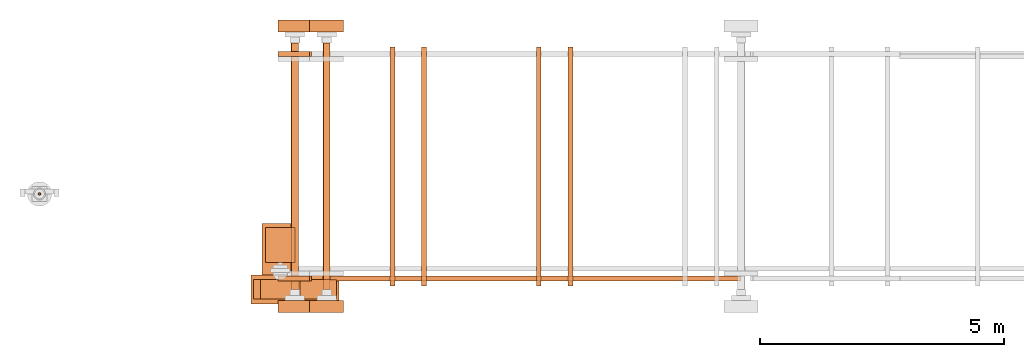
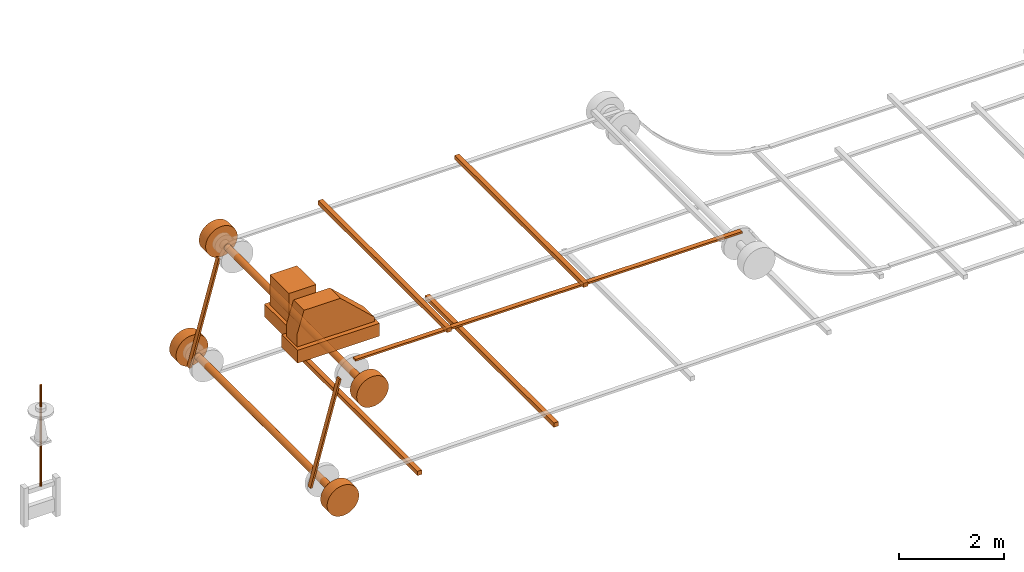
# One storey, part 1 of 6: 27 proxies.
"""IFC2X3 building model written with IfcOpenShell, lengths in millimetres."""

from ifc_helpers import new_model, entity, si_unit, converted_unit, direction, frame, origin_with_axes, origin_2d_with_axis, place, context, project, spatial, polyline, rectangle, circle, outline, extrude, source, transform, mapped, element, save


model = new_model("IFC2X3")

# Units and contexts
model_context = context("Model", 3, precision=1e-05, world=origin_with_axes(), true_north=direction((0.0, 1.0)))
ifc_project = project(units=[si_unit("LENGTHUNIT", "METRE", prefix="MILLI"), si_unit("AREAUNIT", "SQUARE_METRE"), si_unit("VOLUMEUNIT", "CUBIC_METRE"), converted_unit("PLANEANGLEUNIT", "DEGREE", entity("IfcPlaneAngleMeasure", 0.017453293), si_unit("PLANEANGLEUNIT", "RADIAN"), dimensions=[0, 0, 0, 0, 0, 0, 0]), si_unit("SOLIDANGLEUNIT", "STERADIAN"), si_unit("MASSUNIT", "GRAM"), si_unit("TIMEUNIT", "SECOND"), si_unit("THERMODYNAMICTEMPERATUREUNIT", "DEGREE_CELSIUS"), si_unit("LUMINOUSINTENSITYUNIT", "LUMEN")], contexts=[model_context])

# Site, building, storey
site_placement = place(None, origin_with_axes())
site = spatial("IfcSite", under=ifc_project, at=site_placement, CompositionType="ELEMENT")
building_placement = place(site_placement, origin_with_axes())
building = spatial("IfcBuilding", under=site, at=building_placement, Name="Default Building", CompositionType="ELEMENT")
storey_placement = place(building_placement, frame((0.0, 0.0, 16000.0), z_axis=(0.0, 0.0, 1.0), x_axis=(1.0, 0.0, 0.0)))
storey = spatial("IfcBuildingStorey", under=building, at=storey_placement, Name="3FL", CompositionType="ELEMENT", Elevation=16000.0)

# Proxies
shared_shape_1 = source(origin_with_axes(), model_context, "Body", "SweptSolid", [
    extrude(circle(Radius=25.0, at=origin_2d_with_axis()), origin_with_axes(), (0.0, 0.0, 1.0), 2350.0),
])
proxy_1_placement = place(storey_placement, frame((11140.362524, 23295.346832, 1533.035808), z_axis=(0.0, 0.0, 1.0), x_axis=(1.0, 0.0, 0.0)))
element("IfcBuildingElementProxy", 1, at=proxy_1_placement, inside=storey, context=model_context, shape_type="MappedRepresentation", body=[
    mapped(shared_shape_1, transform((0.0, 0.0, 0.0))),
])
shared_shape_2 = source(origin_with_axes(), model_context, "Body", "SweptSolid", [
    extrude(circle(Radius=350.0, at=origin_2d_with_axis()), frame((0.0, 0.0, 0.0), z_axis=(-4.43734259186819e-31, -2.95822839457879e-31, 1.0), x_axis=(1.0, 5.91669923873109e-47, 4.43734259186819e-31)), (0.0, 0.0, 1.0), 250.0),
])
proxy_2_placement = place(storey_placement, frame((16376.115417, 20861.795807, 836.521767), z_axis=(2.22044604925031e-16, 1.0, 1.60814287233912e-16), x_axis=(4.93038065763132e-32, 1.60814287233912e-16, -1.0)))
element("IfcBuildingElementProxy", 2, at=proxy_2_placement, inside=storey, context=model_context, shape_type="MappedRepresentation", body=[
    mapped(shared_shape_2, transform((0.0, 0.0, 0.0))),
])
shared_shape_3 = source(origin_with_axes(), model_context, "Body", "SweptSolid", [
    extrude(rectangle(XDim=100.0, YDim=4900.0, at=origin_2d_with_axis()), origin_with_axes(), (0.0, 0.0, 1.0), 100.0),
])
proxy_3_placement = place(storey_placement, frame((18376.115454, 23861.796014, 395.200808), z_axis=(0.0, 0.0, 1.0), x_axis=(1.0, 0.0, 0.0)))
element("IfcBuildingElementProxy", 3, at=proxy_3_placement, inside=storey, context=model_context, shape_type="MappedRepresentation", body=[
    mapped(shared_shape_3, transform((0.0, 0.0, 0.0))),
])
shared_shape_4 = source(origin_with_axes(), model_context, "Body", "SweptSolid", [
    extrude(outline(polyline([(-1198.796501, -19.752936), (1209.725039, -19.752936), (1197.960199, 22.776105), (-1198.796501, 22.776105), (-1198.796501, -19.752936)])), frame((0.0, 0.0, 0.0), z_axis=(2.43389396721937e-32, 3.84584135769826e-33, 1.0), x_axis=(1.0, 5.71916645986104e-18, -4.35741649917612e-32)), (0.0, 0.0, 1.0), 100.0),
])
proxy_4_placement = place(storey_placement, frame((16374.079133, 26211.795807, 1997.191257), z_axis=(-8.91995163426052e-17, -1.0, 6.95977817373063e-17), x_axis=(-0.266617368178496, -4.32963728535968e-17, -0.963802458486993)))
element("IfcBuildingElementProxy", 4, at=proxy_4_placement, inside=storey, context=model_context, shape_type="MappedRepresentation", body=[
    mapped(shared_shape_4, transform((0.0, 0.0, 0.0))),
])
shared_shape_5 = source(origin_with_axes(), model_context, "Body", "SweptSolid", [
    extrude(outline(polyline([(-1198.796501, -19.752936), (1209.725039, -19.752936), (1197.960199, 22.776105), (-1198.796501, 22.776105), (-1198.796501, -19.752936)])), frame((0.0, 0.0, 0.0), z_axis=(2.43389396721937e-32, 3.84584135769826e-33, 1.0), x_axis=(1.0, 5.71916645986104e-18, -4.35741649917612e-32)), (0.0, 0.0, 1.0), 100.0),
])
proxy_5_placement = place(storey_placement, frame((16374.079133, 21611.795807, 1997.191257), z_axis=(-8.91995163426052e-17, -1.0, 6.95977817373063e-17), x_axis=(-0.266617368178496, -4.32963728535968e-17, -0.963802458486993)))
element("IfcBuildingElementProxy", 5, at=proxy_5_placement, inside=storey, context=model_context, shape_type="MappedRepresentation", body=[
    mapped(shared_shape_5, transform((0.0, 0.0, 0.0))),
])
shared_shape_6 = source(origin_with_axes(), model_context, "Body", "SweptSolid", [
    extrude(outline(polyline([(-4250.0, -21.26452), (4250.0, -21.26452), (4250.0, 21.26452), (-4250.0, 21.26452), (-4250.0, -21.26452)])), origin_with_axes(), (0.0, 0.0, 1.0), 100.0),
])
proxy_6_placement = place(storey_placement, frame((21276.115417, 21611.795807, 3467.786287), z_axis=(0.0, -1.0, 0.0), x_axis=(1.0, 0.0, 0.0)))
element("IfcBuildingElementProxy", 6, at=proxy_6_placement, inside=storey, context=model_context, shape_type="MappedRepresentation", body=[
    mapped(shared_shape_6, transform((0.0, 0.0, 0.0))),
])
shared_shape_7 = source(origin_with_axes(), model_context, "Body", "SweptSolid", [
    extrude(circle(Radius=75.0, at=origin_2d_with_axis()), frame((0.0, 0.0, 0.0), z_axis=(-4.43734259186819e-31, -2.95822839457879e-31, 1.0), x_axis=(1.0, 5.91669923873109e-47, 4.43734259186819e-31)), (0.0, 0.0, 1.0), 5050.0),
])
proxy_7_placement = place(storey_placement, frame((17026.115417, 21336.795807, 3139.050808), z_axis=(2.22044604925031e-16, 1.0, 1.60814287233912e-16), x_axis=(4.93038065763132e-32, 1.60814287233912e-16, -1.0)))
element("IfcBuildingElementProxy", 7, at=proxy_7_placement, inside=storey, context=model_context, shape_type="MappedRepresentation", body=[
    mapped(shared_shape_7, transform((0.0, 0.0, 0.0))),
])
shared_shape_8 = source(origin_with_axes(), model_context, "Body", "SweptSolid", [
    extrude(circle(Radius=350.0, at=origin_2d_with_axis()), frame((0.0, 0.0, 0.0), z_axis=(-4.43734259186819e-31, -2.95822839457879e-31, 1.0), x_axis=(1.0, 5.91669923873109e-47, 4.43734259186819e-31)), (0.0, 0.0, 1.0), 250.0),
])
proxy_8_placement = place(storey_placement, frame((17026.115417, 26611.795807, 3139.050808), z_axis=(2.22044604925031e-16, 1.0, 1.60814287233912e-16), x_axis=(4.93038065763132e-32, 1.60814287233912e-16, -1.0)))
element("IfcBuildingElementProxy", 8, at=proxy_8_placement, inside=storey, context=model_context, shape_type="MappedRepresentation", body=[
    mapped(shared_shape_8, transform((0.0, 0.0, 0.0))),
])
shared_shape_9 = source(origin_with_axes(), model_context, "Body", "SweptSolid", [
    extrude(circle(Radius=350.0, at=origin_2d_with_axis()), frame((0.0, 0.0, 0.0), z_axis=(-4.43734259186819e-31, -2.95822839457879e-31, 1.0), x_axis=(1.0, 5.91669923873109e-47, 4.43734259186819e-31)), (0.0, 0.0, 1.0), 250.0),
])
proxy_9_placement = place(storey_placement, frame((17026.115417, 20861.795807, 3139.050808), z_axis=(2.22044604925031e-16, 1.0, 1.60814287233912e-16), x_axis=(4.93038065763132e-32, 1.60814287233912e-16, -1.0)))
element("IfcBuildingElementProxy", 9, at=proxy_9_placement, inside=storey, context=model_context, shape_type="MappedRepresentation", body=[
    mapped(shared_shape_9, transform((0.0, 0.0, 0.0))),
])
shared_shape_10 = source(origin_with_axes(), model_context, "Body", "SweptSolid", [
    extrude(rectangle(XDim=100.0, YDim=4900.0, at=origin_2d_with_axis()), origin_with_axes(), (0.0, 0.0, 1.0), 100.0),
])
proxy_10_placement = place(storey_placement, frame((21376.115454, 23861.796014, 465.200808), z_axis=(0.0, 0.0, 1.0), x_axis=(1.0, 0.0, 0.0)))
element("IfcBuildingElementProxy", 10, at=proxy_10_placement, inside=storey, context=model_context, shape_type="MappedRepresentation", body=[
    mapped(shared_shape_10, transform((0.0, 0.0, 0.0))),
])
shared_shape_11 = source(origin_with_axes(), model_context, "Body", "SweptSolid", [
    extrude(circle(Radius=75.0, at=origin_2d_with_axis()), frame((0.0, 0.0, 0.0), z_axis=(-4.43734259186819e-31, -2.95822839457879e-31, 1.0), x_axis=(1.0, 5.91669923873109e-47, 4.43734259186819e-31)), (0.0, 0.0, 1.0), 5050.0),
])
proxy_11_placement = place(storey_placement, frame((16376.115417, 21336.795807, 836.521767), z_axis=(2.22044604925031e-16, 1.0, 1.60814287233912e-16), x_axis=(4.93038065763132e-32, 1.60814287233912e-16, -1.0)))
element("IfcBuildingElementProxy", 11, at=proxy_11_placement, inside=storey, context=model_context, shape_type="MappedRepresentation", body=[
    mapped(shared_shape_11, transform((0.0, 0.0, 0.0))),
])
shared_shape_12 = source(origin_with_axes(), model_context, "Body", "SweptSolid", [
    extrude(circle(Radius=350.0, at=origin_2d_with_axis()), frame((0.0, 0.0, 0.0), z_axis=(-4.43734259186819e-31, -2.95822839457879e-31, 1.0), x_axis=(1.0, 5.91669923873109e-47, 4.43734259186819e-31)), (0.0, 0.0, 1.0), 250.0),
])
proxy_12_placement = place(storey_placement, frame((16376.115417, 26611.795807, 836.521767), z_axis=(2.22044604925031e-16, 1.0, 1.60814287233912e-16), x_axis=(4.93038065763132e-32, 1.60814287233912e-16, -1.0)))
element("IfcBuildingElementProxy", 12, at=proxy_12_placement, inside=storey, context=model_context, shape_type="MappedRepresentation", body=[
    mapped(shared_shape_12, transform((0.0, 0.0, 0.0))),
])
shared_shape_13 = source(origin_with_axes(), model_context, "Body", "SweptSolid", [
    extrude(circle(Radius=350.0, at=origin_2d_with_axis()), frame((0.0, 0.0, 0.0), z_axis=(-4.43734259186819e-31, -2.95822839457879e-31, 1.0), x_axis=(1.0, 5.91669923873109e-47, 4.43734259186819e-31)), (0.0, 0.0, 1.0), 250.0),
])
proxy_13_placement = place(storey_placement, frame((16376.115417, 20861.795807, 836.521767), z_axis=(2.22044604925031e-16, 1.0, 1.60814287233912e-16), x_axis=(4.93038065763132e-32, 1.60814287233912e-16, -1.0)))
element("IfcBuildingElementProxy", 13, at=proxy_13_placement, inside=storey, context=model_context, shape_type="MappedRepresentation", body=[
    mapped(shared_shape_13, transform((0.0, 0.0, 0.0))),
])
shared_shape_14 = source(origin_with_axes(), model_context, "Body", "SweptSolid", [
    extrude(outline(polyline([(-1198.796501, -19.752936), (1209.725039, -19.752936), (1197.960199, 22.776105), (-1198.796501, 22.776105), (-1198.796501, -19.752936)])), frame((0.0, 0.0, 0.0), z_axis=(2.43389396721937e-32, 3.84584135769826e-33, 1.0), x_axis=(1.0, 5.71916645986104e-18, -4.35741649917612e-32)), (0.0, 0.0, 1.0), 100.0),
])
proxy_14_placement = place(storey_placement, frame((16374.079133, 26211.795807, 1997.191257), z_axis=(-8.91995163426052e-17, -1.0, 6.95977817373063e-17), x_axis=(-0.266617368178496, -4.32963728535968e-17, -0.963802458486993)))
element("IfcBuildingElementProxy", 14, at=proxy_14_placement, inside=storey, context=model_context, shape_type="MappedRepresentation", body=[
    mapped(shared_shape_14, transform((0.0, 0.0, 0.0))),
])
shared_shape_15 = source(origin_with_axes(), model_context, "Body", "SweptSolid", [
    extrude(outline(polyline([(-1198.796501, -19.752936), (1209.725039, -19.752936), (1197.960199, 22.776105), (-1198.796501, 22.776105), (-1198.796501, -19.752936)])), frame((0.0, 0.0, 0.0), z_axis=(2.43389396721937e-32, 3.84584135769826e-33, 1.0), x_axis=(1.0, 5.71916645986104e-18, -4.35741649917612e-32)), (0.0, 0.0, 1.0), 100.0),
])
proxy_15_placement = place(storey_placement, frame((16374.079133, 21611.795807, 1997.191257), z_axis=(-8.91995163426052e-17, -1.0, 6.95977817373063e-17), x_axis=(-0.266617368178496, -4.32963728535968e-17, -0.963802458486993)))
element("IfcBuildingElementProxy", 15, at=proxy_15_placement, inside=storey, context=model_context, shape_type="MappedRepresentation", body=[
    mapped(shared_shape_15, transform((0.0, 0.0, 0.0))),
])
shared_shape_16 = source(origin_with_axes(), model_context, "Body", "SweptSolid", [
    extrude(outline(polyline([(-4250.0, -21.26452), (4250.0, -21.26452), (4250.0, 21.26452), (-4250.0, 21.26452), (-4250.0, -21.26452)])), origin_with_axes(), (0.0, 0.0, 1.0), 100.0),
])
proxy_16_placement = place(storey_placement, frame((21276.115417, 21611.795807, 3467.786287), z_axis=(0.0, -1.0, 0.0), x_axis=(1.0, 0.0, 0.0)))
element("IfcBuildingElementProxy", 16, at=proxy_16_placement, inside=storey, context=model_context, shape_type="MappedRepresentation", body=[
    mapped(shared_shape_16, transform((0.0, 0.0, 0.0))),
])
shared_shape_17 = source(origin_with_axes(), model_context, "Body", "SweptSolid", [
    extrude(circle(Radius=75.0, at=origin_2d_with_axis()), frame((0.0, 0.0, 0.0), z_axis=(-4.43734259186819e-31, -2.95822839457879e-31, 1.0), x_axis=(1.0, 5.91669923873109e-47, 4.43734259186819e-31)), (0.0, 0.0, 1.0), 5050.0),
])
proxy_17_placement = place(storey_placement, frame((17026.115417, 21336.795807, 3139.050808), z_axis=(2.22044604925031e-16, 1.0, 1.60814287233912e-16), x_axis=(4.93038065763132e-32, 1.60814287233912e-16, -1.0)))
element("IfcBuildingElementProxy", 17, at=proxy_17_placement, inside=storey, context=model_context, shape_type="MappedRepresentation", body=[
    mapped(shared_shape_17, transform((0.0, 0.0, 0.0))),
])
shared_shape_18 = source(origin_with_axes(), model_context, "Body", "SweptSolid", [
    extrude(circle(Radius=350.0, at=origin_2d_with_axis()), frame((0.0, 0.0, 0.0), z_axis=(-4.43734259186819e-31, -2.95822839457879e-31, 1.0), x_axis=(1.0, 5.91669923873109e-47, 4.43734259186819e-31)), (0.0, 0.0, 1.0), 250.0),
])
proxy_18_placement = place(storey_placement, frame((17026.115417, 26611.795807, 3139.050808), z_axis=(2.22044604925031e-16, 1.0, 1.60814287233912e-16), x_axis=(4.93038065763132e-32, 1.60814287233912e-16, -1.0)))
element("IfcBuildingElementProxy", 18, at=proxy_18_placement, inside=storey, context=model_context, shape_type="MappedRepresentation", body=[
    mapped(shared_shape_18, transform((0.0, 0.0, 0.0))),
])
shared_shape_19 = source(origin_with_axes(), model_context, "Body", "SweptSolid", [
    extrude(circle(Radius=350.0, at=origin_2d_with_axis()), frame((0.0, 0.0, 0.0), z_axis=(-4.43734259186819e-31, -2.95822839457879e-31, 1.0), x_axis=(1.0, 5.91669923873109e-47, 4.43734259186819e-31)), (0.0, 0.0, 1.0), 250.0),
])
proxy_19_placement = place(storey_placement, frame((17026.115417, 20861.795807, 3139.050808), z_axis=(2.22044604925031e-16, 1.0, 1.60814287233912e-16), x_axis=(4.93038065763132e-32, 1.60814287233912e-16, -1.0)))
element("IfcBuildingElementProxy", 19, at=proxy_19_placement, inside=storey, context=model_context, shape_type="MappedRepresentation", body=[
    mapped(shared_shape_19, transform((0.0, 0.0, 0.0))),
])
shared_shape_20 = source(origin_with_axes(), model_context, "Body", "SweptSolid", [
    extrude(rectangle(XDim=100.0, YDim=4900.0, at=origin_2d_with_axis()), origin_with_axes(), (0.0, 0.0, 1.0), 100.0),
])
proxy_20_placement = place(storey_placement, frame((19026.115454, 23861.796014, 3489.050808), z_axis=(0.0, 0.0, 1.0), x_axis=(1.0, 0.0, 0.0)))
element("IfcBuildingElementProxy", 20, at=proxy_20_placement, inside=storey, context=model_context, shape_type="MappedRepresentation", body=[
    mapped(shared_shape_20, transform((0.0, 0.0, 0.0))),
])
shared_shape_21 = source(origin_with_axes(), model_context, "Body", "SweptSolid", [
    extrude(circle(Radius=75.0, at=origin_2d_with_axis()), frame((0.0, 0.0, 0.0), z_axis=(-4.43734259186819e-31, -2.95822839457879e-31, 1.0), x_axis=(1.0, 5.91669923873109e-47, 4.43734259186819e-31)), (0.0, 0.0, 1.0), 5050.0),
])
proxy_21_placement = place(storey_placement, frame((16376.115417, 21336.795807, 836.521767), z_axis=(2.22044604925031e-16, 1.0, 1.60814287233912e-16), x_axis=(4.93038065763132e-32, 1.60814287233912e-16, -1.0)))
element("IfcBuildingElementProxy", 21, at=proxy_21_placement, inside=storey, context=model_context, shape_type="MappedRepresentation", body=[
    mapped(shared_shape_21, transform((0.0, 0.0, 0.0))),
])
shared_shape_22 = source(origin_with_axes(), model_context, "Body", "SweptSolid", [
    extrude(circle(Radius=350.0, at=origin_2d_with_axis()), frame((0.0, 0.0, 0.0), z_axis=(-4.43734259186819e-31, -2.95822839457879e-31, 1.0), x_axis=(1.0, 5.91669923873109e-47, 4.43734259186819e-31)), (0.0, 0.0, 1.0), 250.0),
])
proxy_22_placement = place(storey_placement, frame((16376.115417, 26611.795807, 836.521767), z_axis=(2.22044604925031e-16, 1.0, 1.60814287233912e-16), x_axis=(4.93038065763132e-32, 1.60814287233912e-16, -1.0)))
element("IfcBuildingElementProxy", 22, at=proxy_22_placement, inside=storey, context=model_context, shape_type="MappedRepresentation", body=[
    mapped(shared_shape_22, transform((0.0, 0.0, 0.0))),
])
shared_shape_23 = source(origin_with_axes(), model_context, "Body", "SweptSolid", [
    extrude(rectangle(XDim=100.0, YDim=4900.0, at=origin_2d_with_axis()), origin_with_axes(), (0.0, 0.0, 1.0), 100.0),
])
proxy_23_placement = place(storey_placement, frame((22026.115454, 23861.796014, 3489.050808), z_axis=(0.0, 0.0, 1.0), x_axis=(1.0, 0.0, 0.0)))
element("IfcBuildingElementProxy", 23, at=proxy_23_placement, inside=storey, context=model_context, shape_type="MappedRepresentation", body=[
    mapped(shared_shape_23, transform((0.0, 0.0, 0.0))),
])
shared_shape_24 = source(origin_with_axes(), model_context, "Body", "SweptSolid", [
    extrude(rectangle(XDim=1800.0, YDim=600.0, at=origin_2d_with_axis()), origin_with_axes(), (0.0, 0.0, 1.0), 300.0),
])
proxy_24_placement = place(storey_placement, frame((16376.115417, 21336.795807, 4232.050808), z_axis=(0.0, 0.0, 1.0), x_axis=(1.0, 0.0, 0.0)))
element("IfcBuildingElementProxy", 24, at=proxy_24_placement, inside=storey, context=model_context, shape_type="MappedRepresentation", body=[
    mapped(shared_shape_24, transform((0.0, 0.0, 0.0))),
])
shared_shape_25 = source(origin_with_axes(), model_context, "Body", "SweptSolid", [
    extrude(rectangle(XDim=600.0, YDim=725.000000000184, at=origin_2d_with_axis()), origin_with_axes(), (0.0, 0.0, 1.0), 700.0),
])
proxy_25_placement = place(storey_placement, frame((16076.115417, 22249.295807, 4532.050808), z_axis=(0.0, 0.0, 1.0), x_axis=(1.0, 0.0, 0.0)))
element("IfcBuildingElementProxy", 25, at=proxy_25_placement, inside=storey, context=model_context, shape_type="MappedRepresentation", body=[
    mapped(shared_shape_25, transform((0.0, 0.0, 0.0))),
])
shared_shape_26 = source(origin_with_axes(), model_context, "Body", "SweptSolid", [
    extrude(rectangle(XDim=750.0, YDim=1050.00000000003, at=origin_2d_with_axis()), origin_with_axes(), (0.0, 0.0, 1.0), 300.0),
])
proxy_26_placement = place(storey_placement, frame((16076.115417, 22161.795807, 4232.050808), z_axis=(0.0, 0.0, 1.0), x_axis=(1.0, 0.0, 0.0)))
element("IfcBuildingElementProxy", 26, at=proxy_26_placement, inside=storey, context=model_context, shape_type="MappedRepresentation", body=[
    mapped(shared_shape_26, transform((0.0, 0.0, 0.0))),
])
shared_shape_27 = source(origin_with_axes(), model_context, "Body", "SweptSolid", [
    extrude(outline(polyline([(850.0, -400.0), (850.0, -300.0), (100.0, 400.0), (-700.0, 400.0), (-850.0, -100.0), (-850.0, -400.0), (850.0, -400.0)])), origin_with_axes(), (0.0, 0.0, 1.0), 400.0),
])
proxy_27_placement = place(storey_placement, frame((16376.115417, 21536.795807, 4932.050808), z_axis=(0.0, -1.0, 0.0), x_axis=(1.0, 0.0, 0.0)))
element("IfcBuildingElementProxy", 27, at=proxy_27_placement, inside=storey, context=model_context, shape_type="MappedRepresentation", body=[
    mapped(shared_shape_27, transform((0.0, 0.0, 0.0))),
])

save(model, "model.ifc")
